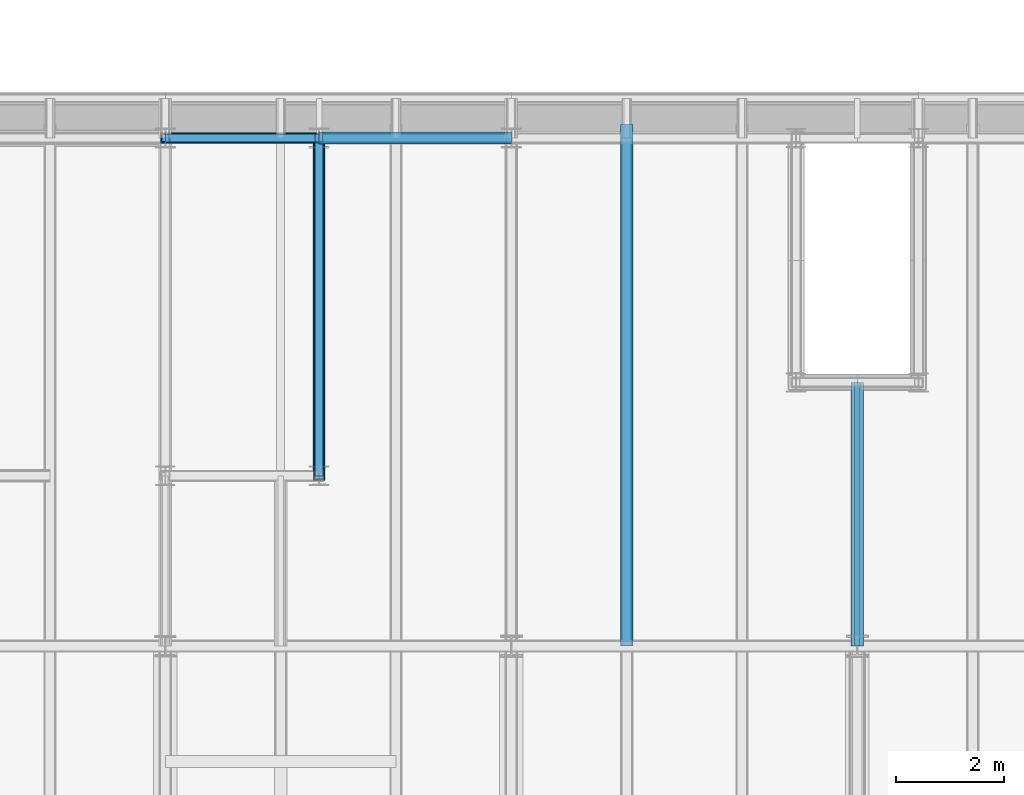
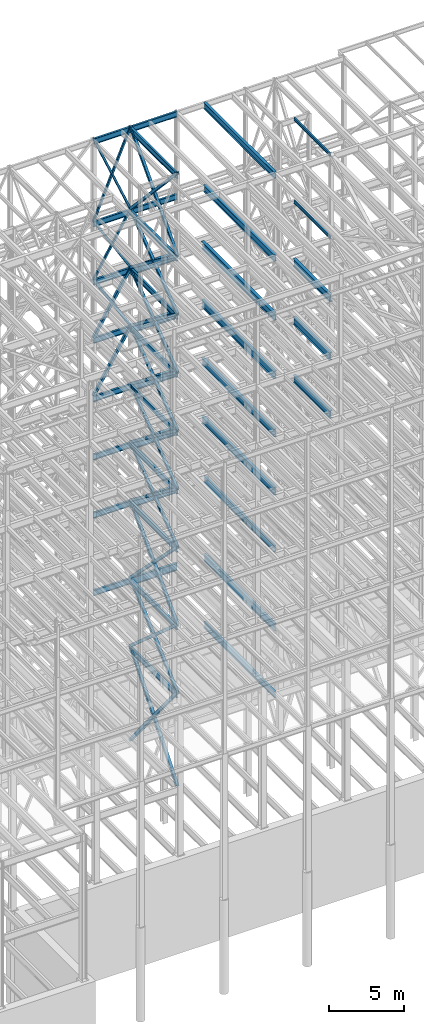
# One storey, part 142 of 150: 64 beams.
"""IFC2X3 building model written with IfcOpenShell, lengths in millimetres."""

from ifc_helpers import new_model, si_unit, frame, origin_with_axes, origin_2d_with_axis, place, context, subcontext, project, spatial, hollow_rectangle, i_section, extrude, material, type_object, element, save


model = new_model("IFC2X3")

# Units and contexts
model_context = context("Model", 3, precision=1e-05, world=origin_with_axes())
body_context = subcontext(model_context, "Body", "Model", "MODEL_VIEW")
ifc_project = project(units=[si_unit("LENGTHUNIT", "METRE", prefix="MILLI"), si_unit("AREAUNIT", "SQUARE_METRE"), si_unit("VOLUMEUNIT", "CUBIC_METRE"), si_unit("MASSUNIT", "GRAM", prefix="KILO"), si_unit("TIMEUNIT", "SECOND"), si_unit("PLANEANGLEUNIT", "RADIAN"), si_unit("SOLIDANGLEUNIT", "STERADIAN"), si_unit("THERMODYNAMICTEMPERATUREUNIT", "DEGREE_CELSIUS"), si_unit("LUMINOUSINTENSITYUNIT", "LUMEN")], contexts=[model_context])

# Site, building, storey
site_placement = place(None, origin_with_axes())
site = spatial("IfcSite", under=ifc_project, at=site_placement, CompositionType="ELEMENT")
building_placement = place(site_placement, origin_with_axes())
building = spatial("IfcBuilding", under=site, at=building_placement, Name="Undefined", CompositionType="ELEMENT")
storey_placement = place(building_placement, origin_with_axes())
storey = spatial("IfcBuildingStorey", under=building, at=storey_placement, Name="Undefined", CompositionType="ELEMENT", Elevation=0.0)

# Beams
ifc_material_1 = material()
beam_type_1 = type_object("IfcBeamType", Name="HSS8X8X3/8", PredefinedType="NOTDEFINED")
for number, where, z_axis, x_axis, name in (
    (1, (65836.8, 31877.0, 40309.8), (0.0, 0.603108242282795, 0.797659355922412), (0.0, -0.797659355922412, 0.603108242282795), "BEAM"),
    (2, (65836.8, 25628.6, 35585.4), (0.0, -0.603108242282795, 0.797659355922412), (0.0, 0.797659355922412, 0.603108242282795), "BEAM"),
    (3, (65836.8, 25628.6, 40309.8), (0.0, -0.603108242282795, 0.797659355922412), (0.0, 0.797659355922412, 0.603108242282795), "BEAM"),
    (4, (65836.8, 31877.0, 35585.4), (0.0, 0.603108242282795, 0.797659355922412), (0.0, -0.797659355922412, 0.603108242282795), "BEAM"),
):
    element("IfcBeam", number, at=place(storey_placement, frame(where, z_axis=z_axis, x_axis=x_axis)), inside=storey, type_object=beam_type_1, material=ifc_material_1, Name=name, ObjectType="HSS8X8X3/8", context=body_context, shape_type="SweptSolid", body=[
        extrude(hollow_rectangle(XDim=203.2, YDim=203.2, WallThickness=9.525, InnerFilletRadius=9.5249, OuterFilletRadius=19.0499, at=origin_2d_with_axis()), frame((7833.41929938644, 0.0, 0.0), z_axis=(-1.0, 0.0, 0.0), x_axis=(0.0, -1.0, 0.0)), (0.0, 0.0, 1.0), 7833.41929938644),
    ])
ifc_material_2 = material(Name="STEEL/A992")
beam_type_2 = type_object("IfcBeamType", Name="W18X35", PredefinedType="NOTDEFINED")
beam_1_placement = place(storey_placement, frame((62992.0, 31877.0, 65687.575), z_axis=(0.0, 0.0, 1.0), x_axis=(1.0, 0.0, 0.0)))
element("IfcBeam", 5, at=beam_1_placement, inside=storey, type_object=beam_type_2, material=ifc_material_2, Name="BEAM", ObjectType="W18X35", context=body_context, shape_type="SweptSolid", body=[
    extrude(i_section(OverallWidth=152.4, OverallDepth=450.85, WebThickness=7.9375, FlangeThickness=10.795, FilletRadius=17.78, at=origin_2d_with_axis()), frame((2844.8, 0.0, 0.0), z_axis=(-1.0, 0.0, 0.0), x_axis=(0.0, -1.0, 0.0)), (0.0, 0.0, 1.0), 2844.8),
])
beam_2_placement = place(storey_placement, frame((65836.8, 31877.0, 65687.575), z_axis=(0.0, 0.0, 1.0), x_axis=(1.0, 0.0, 0.0)))
element("IfcBeam", 6, at=beam_2_placement, inside=storey, type_object=beam_type_2, material=ifc_material_2, Name="BEAM", ObjectType="W18X35", context=body_context, shape_type="SweptSolid", body=[
    extrude(i_section(OverallWidth=152.4, OverallDepth=450.85, WebThickness=7.9375, FlangeThickness=10.795, FilletRadius=17.78, at=origin_2d_with_axis()), frame((3556.0, 0.0, 0.0), z_axis=(-1.0, 0.0, 0.0), x_axis=(0.0, -1.0, 0.0)), (0.0, 0.0, 1.0), 3556.0),
])
beam_3_placement = place(storey_placement, frame((62992.0, 31877.0, 58981.975), z_axis=(0.0, 0.0, 1.0), x_axis=(1.0, 0.0, 0.0)))
element("IfcBeam", 7, at=beam_3_placement, inside=storey, type_object=beam_type_2, material=ifc_material_2, Name="BEAM", ObjectType="W18X35", context=body_context, shape_type="SweptSolid", body=[
    extrude(i_section(OverallWidth=152.4, OverallDepth=450.85, WebThickness=7.9375, FlangeThickness=10.795, FilletRadius=17.78, at=origin_2d_with_axis()), frame((2844.8, 0.0, 0.0), z_axis=(-1.0, 0.0, 0.0), x_axis=(0.0, -1.0, 0.0)), (0.0, 0.0, 1.0), 2844.8),
])
beam_4_placement = place(storey_placement, frame((65836.8, 25628.6, 58981.975), z_axis=(0.0, 0.0, 1.0), x_axis=(0.0, 1.0, 0.0)))
element("IfcBeam", 8, at=beam_4_placement, inside=storey, type_object=beam_type_2, material=ifc_material_2, Name="BEAM", ObjectType="W18X35", context=body_context, shape_type="SweptSolid", body=[
    extrude(i_section(OverallWidth=152.4, OverallDepth=450.85, WebThickness=7.9375, FlangeThickness=10.795, FilletRadius=17.78, at=origin_2d_with_axis()), frame((6248.40000000001, 0.0, 0.0), z_axis=(-1.0, 0.0, 0.0), x_axis=(0.0, -1.0, 0.0)), (0.0, 0.0, 1.0), 6248.40000000001),
])
beam_5_placement = place(storey_placement, frame((65836.8, 31877.0, 58981.975), z_axis=(0.0, 0.0, 1.0), x_axis=(1.0, 0.0, 0.0)))
element("IfcBeam", 9, at=beam_5_placement, inside=storey, type_object=beam_type_2, material=ifc_material_2, Name="BEAM", ObjectType="W18X35", context=body_context, shape_type="SweptSolid", body=[
    extrude(i_section(OverallWidth=152.4, OverallDepth=450.85, WebThickness=7.9375, FlangeThickness=10.795, FilletRadius=17.78, at=origin_2d_with_axis()), frame((3556.0, 0.0, 0.0), z_axis=(-1.0, 0.0, 0.0), x_axis=(0.0, -1.0, 0.0)), (0.0, 0.0, 1.0), 3556.0),
])
beam_6_placement = place(storey_placement, frame((62992.0, 31877.0, 54257.575), z_axis=(0.0, 0.0, 1.0), x_axis=(1.0, 0.0, 0.0)))
element("IfcBeam", 10, at=beam_6_placement, inside=storey, type_object=beam_type_2, material=ifc_material_2, Name="BEAM", ObjectType="W18X35", context=body_context, shape_type="SweptSolid", body=[
    extrude(i_section(OverallWidth=152.4, OverallDepth=450.85, WebThickness=7.9375, FlangeThickness=10.795, FilletRadius=17.78, at=origin_2d_with_axis()), frame((2844.8, 0.0, 0.0), z_axis=(-1.0, 0.0, 0.0), x_axis=(0.0, -1.0, 0.0)), (0.0, 0.0, 1.0), 2844.8),
])
beam_7_placement = place(storey_placement, frame((65836.8, 25628.6, 54257.575), z_axis=(0.0, 0.0, 1.0), x_axis=(0.0, 1.0, 0.0)))
element("IfcBeam", 11, at=beam_7_placement, inside=storey, type_object=beam_type_2, material=ifc_material_2, Name="BEAM", ObjectType="W18X35", context=body_context, shape_type="SweptSolid", body=[
    extrude(i_section(OverallWidth=152.4, OverallDepth=450.85, WebThickness=7.9375, FlangeThickness=10.795, FilletRadius=17.78, at=origin_2d_with_axis()), frame((6248.40000000001, 0.0, 0.0), z_axis=(-1.0, 0.0, 0.0), x_axis=(0.0, -1.0, 0.0)), (0.0, 0.0, 1.0), 6248.40000000001),
])
beam_8_placement = place(storey_placement, frame((62992.0, 31877.0, 49533.175), z_axis=(0.0, 0.0, 1.0), x_axis=(1.0, 0.0, 0.0)))
element("IfcBeam", 12, at=beam_8_placement, inside=storey, type_object=beam_type_2, material=ifc_material_2, Name="BEAM", ObjectType="W18X35", context=body_context, shape_type="SweptSolid", body=[
    extrude(i_section(OverallWidth=152.4, OverallDepth=450.85, WebThickness=7.9375, FlangeThickness=10.795, FilletRadius=17.78, at=origin_2d_with_axis()), frame((2844.8, 0.0, 0.0), z_axis=(-1.0, 0.0, 0.0), x_axis=(0.0, -1.0, 0.0)), (0.0, 0.0, 1.0), 2844.8),
])
beam_9_placement = place(storey_placement, frame((65836.8, 25628.6, 49533.175), z_axis=(0.0, 0.0, 1.0), x_axis=(0.0, 1.0, 0.0)))
element("IfcBeam", 13, at=beam_9_placement, inside=storey, type_object=beam_type_2, material=ifc_material_2, Name="BEAM", ObjectType="W18X35", context=body_context, shape_type="SweptSolid", body=[
    extrude(i_section(OverallWidth=152.4, OverallDepth=450.85, WebThickness=7.9375, FlangeThickness=10.795, FilletRadius=17.78, at=origin_2d_with_axis()), frame((6248.40000000001, 0.0, 0.0), z_axis=(-1.0, 0.0, 0.0), x_axis=(0.0, -1.0, 0.0)), (0.0, 0.0, 1.0), 6248.40000000001),
])
beam_10_placement = place(storey_placement, frame((62992.0, 31877.0, 44808.775), z_axis=(0.0, 0.0, 1.0), x_axis=(1.0, 0.0, 0.0)))
element("IfcBeam", 14, at=beam_10_placement, inside=storey, type_object=beam_type_2, material=ifc_material_2, Name="BEAM", ObjectType="W18X35", context=body_context, shape_type="SweptSolid", body=[
    extrude(i_section(OverallWidth=152.4, OverallDepth=450.85, WebThickness=7.9375, FlangeThickness=10.795, FilletRadius=17.78, at=origin_2d_with_axis()), frame((2844.8, 0.0, 0.0), z_axis=(-1.0, 0.0, 0.0), x_axis=(0.0, -1.0, 0.0)), (0.0, 0.0, 1.0), 2844.8),
])
beam_11_placement = place(storey_placement, frame((65836.8, 25628.6, 44808.775), z_axis=(0.0, 0.0, 1.0), x_axis=(0.0, 1.0, 0.0)))
element("IfcBeam", 15, at=beam_11_placement, inside=storey, type_object=beam_type_2, material=ifc_material_2, Name="BEAM", ObjectType="W18X35", context=body_context, shape_type="SweptSolid", body=[
    extrude(i_section(OverallWidth=152.4, OverallDepth=450.85, WebThickness=7.9375, FlangeThickness=10.795, FilletRadius=17.78, at=origin_2d_with_axis()), frame((6248.40000000001, 0.0, 0.0), z_axis=(-1.0, 0.0, 0.0), x_axis=(0.0, -1.0, 0.0)), (0.0, 0.0, 1.0), 6248.40000000001),
])
beam_12_placement = place(storey_placement, frame((62992.0, 31877.0, 40084.375), z_axis=(0.0, 0.0, 1.0), x_axis=(1.0, 0.0, 0.0)))
element("IfcBeam", 16, at=beam_12_placement, inside=storey, type_object=beam_type_2, material=ifc_material_2, Name="BEAM", ObjectType="W18X35", context=body_context, shape_type="SweptSolid", body=[
    extrude(i_section(OverallWidth=152.4, OverallDepth=450.85, WebThickness=7.9375, FlangeThickness=10.795, FilletRadius=17.78, at=origin_2d_with_axis()), frame((2844.8, 0.0, 0.0), z_axis=(-1.0, 0.0, 0.0), x_axis=(0.0, -1.0, 0.0)), (0.0, 0.0, 1.0), 2844.8),
])
for number, where, z_axis, x_axis, name in (
    (17, (65836.8, 25628.6, 40084.375), (0.0, 0.0, 1.0), (0.0, 1.0, 0.0), "BEAM"),
    (18, (65836.8, 25628.6, 35359.975), (0.0, 0.0, 1.0), (0.0, 1.0, 0.0), "BEAM"),
):
    element("IfcBeam", number, at=place(storey_placement, frame(where, z_axis=z_axis, x_axis=x_axis)), inside=storey, type_object=beam_type_2, material=ifc_material_2, Name=name, ObjectType="W18X35", context=body_context, shape_type="SweptSolid", body=[
        extrude(i_section(OverallWidth=152.4, OverallDepth=450.85, WebThickness=7.9375, FlangeThickness=10.795, FilletRadius=17.78, at=origin_2d_with_axis()), frame((6248.40000000001, 0.0, 0.0), z_axis=(-1.0, 0.0, 0.0), x_axis=(0.0, -1.0, 0.0)), (0.0, 0.0, 1.0), 6248.40000000001),
    ])
beam_13_placement = place(storey_placement, frame((62992.0, 31877.0, 35359.975), z_axis=(0.0, 0.0, 1.0), x_axis=(1.0, 0.0, 0.0)))
element("IfcBeam", 19, at=beam_13_placement, inside=storey, type_object=beam_type_2, material=ifc_material_2, Name="BEAM", ObjectType="W18X35", context=body_context, shape_type="SweptSolid", body=[
    extrude(i_section(OverallWidth=152.4, OverallDepth=450.85, WebThickness=7.9375, FlangeThickness=10.795, FilletRadius=17.78, at=origin_2d_with_axis()), frame((2844.8, 0.0, 0.0), z_axis=(-1.0, 0.0, 0.0), x_axis=(0.0, -1.0, 0.0)), (0.0, 0.0, 1.0), 2844.8),
])
beam_14_placement = place(storey_placement, frame((62992.0, 31877.0, 29060.775), z_axis=(0.0, 0.0, 1.0), x_axis=(1.0, 0.0, 0.0)))
element("IfcBeam", 20, at=beam_14_placement, inside=storey, type_object=beam_type_2, material=ifc_material_2, Name="BEAM", ObjectType="W18X35", context=body_context, shape_type="SweptSolid", body=[
    extrude(i_section(OverallWidth=152.4, OverallDepth=450.85, WebThickness=7.9375, FlangeThickness=10.795, FilletRadius=17.78, at=origin_2d_with_axis()), frame((2844.8, 0.0, 0.0), z_axis=(-1.0, 0.0, 0.0), x_axis=(0.0, -1.0, 0.0)), (0.0, 0.0, 1.0), 2844.79999999999),
])
for number, where, z_axis, x_axis, name in (
    (21, (65836.8, 25628.6, 29060.775), (0.0, 0.0, 1.0), (0.0, 1.0, 0.0), "BEAM"),
    (22, (65836.8, 25628.6, 23548.975), (0.0, 0.0, 1.0), (0.0, 1.0, 0.0), "BEAM"),
):
    element("IfcBeam", number, at=place(storey_placement, frame(where, z_axis=z_axis, x_axis=x_axis)), inside=storey, type_object=beam_type_2, material=ifc_material_2, Name=name, ObjectType="W18X35", context=body_context, shape_type="SweptSolid", body=[
        extrude(i_section(OverallWidth=152.4, OverallDepth=450.85, WebThickness=7.9375, FlangeThickness=10.795, FilletRadius=17.78, at=origin_2d_with_axis()), frame((6248.40000000001, 0.0, 0.0), z_axis=(-1.0, 0.0, 0.0), x_axis=(0.0, -1.0, 0.0)), (0.0, 0.0, 1.0), 6248.40000000001),
    ])
beam_type_3 = type_object("IfcBeamType", Name="HSS8X8X1/4", PredefinedType="NOTDEFINED")
beam_15_placement = place(storey_placement, frame((65836.8, 31877.0, 59207.4), z_axis=(0.0, 0.73160793181113, 0.681725629642191), x_axis=(0.0, -0.681725629642191, 0.731607931811129)))
element("IfcBeam", 23, at=beam_15_placement, inside=storey, type_object=beam_type_3, material=ifc_material_1, Name="BEAM", ObjectType="HSS8X8X1/4", context=body_context, shape_type="SweptSolid", body=[
    extrude(hollow_rectangle(XDim=203.2, YDim=203.2, WallThickness=6.35, InnerFilletRadius=6.3499, OuterFilletRadius=12.6999, at=origin_2d_with_axis()), frame((9165.56457180898, 0.0, -7.27595761418343e-12), z_axis=(-1.0, 0.0, 0.0), x_axis=(0.0, -1.0, 0.0)), (0.0, 0.0, 1.0), 9165.56457180899),
])
for number, where, z_axis, x_axis, name in (
    (24, (65836.8, 25628.6, 54483.0), (0.0, -0.603108242282795, 0.797659355922412), (0.0, 0.797659355922412, 0.603108242282795), "BEAM"),
    (25, (65836.8, 31877.0, 49758.6), (0.0, 0.603108242282795, 0.797659355922412), (0.0, -0.797659355922412, 0.603108242282795), "BEAM"),
    (26, (65836.8, 25628.6, 45034.2), (0.0, -0.603108242282795, 0.797659355922412), (0.0, 0.797659355922412, 0.603108242282795), "BEAM"),
):
    element("IfcBeam", number, at=place(storey_placement, frame(where, z_axis=z_axis, x_axis=x_axis)), inside=storey, type_object=beam_type_3, material=ifc_material_1, Name=name, ObjectType="HSS8X8X1/4", context=body_context, shape_type="SweptSolid", body=[
        extrude(hollow_rectangle(XDim=203.2, YDim=203.2, WallThickness=6.35, InnerFilletRadius=6.3499, OuterFilletRadius=12.6999, at=origin_2d_with_axis()), frame((7833.41929938644, 0.0, 0.0), z_axis=(-1.0, 0.0, 0.0), x_axis=(0.0, -1.0, 0.0)), (0.0, 0.0, 1.0), 7833.41929938644),
    ])
beam_16_placement = place(storey_placement, frame((65836.8, 25628.6, 59207.4), z_axis=(0.0, -0.73160798168672, 0.681725576117168), x_axis=(0.0, 0.681725576117167, 0.731607981686721)))
element("IfcBeam", 27, at=beam_16_placement, inside=storey, type_object=beam_type_3, material=ifc_material_1, Name="BEAM", ObjectType="HSS8X8X1/4", context=body_context, shape_type="SweptSolid", body=[
    extrude(hollow_rectangle(XDim=203.2, YDim=203.2, WallThickness=6.35, InnerFilletRadius=6.3499, OuterFilletRadius=12.6999, at=origin_2d_with_axis()), frame((9165.56457180898, 0.0, -7.27595761418343e-12), z_axis=(-1.0, 0.0, 0.0), x_axis=(0.0, -1.0, 0.0)), (0.0, 0.0, 1.0), 9165.56457180899),
])
for number, where, z_axis, x_axis, name in (
    (28, (65836.8, 31877.0, 54483.0), (0.0, 0.603108242282795, 0.797659355922412), (0.0, -0.797659355922412, 0.603108242282795), "BEAM"),
    (29, (65836.8, 25628.6, 49758.6), (0.0, -0.603108242282795, 0.797659355922412), (0.0, 0.797659355922412, 0.603108242282795), "BEAM"),
    (30, (65836.8, 31877.0, 45034.2), (0.0, 0.603108242282795, 0.797659355922412), (0.0, -0.797659355922412, 0.603108242282795), "BEAM"),
):
    element("IfcBeam", number, at=place(storey_placement, frame(where, z_axis=z_axis, x_axis=x_axis)), inside=storey, type_object=beam_type_3, material=ifc_material_1, Name=name, ObjectType="HSS8X8X1/4", context=body_context, shape_type="SweptSolid", body=[
        extrude(hollow_rectangle(XDim=203.2, YDim=203.2, WallThickness=6.35, InnerFilletRadius=6.3499, OuterFilletRadius=12.6999, at=origin_2d_with_axis()), frame((7833.41929938644, 0.0, 0.0), z_axis=(-1.0, 0.0, 0.0), x_axis=(0.0, -1.0, 0.0)), (0.0, 0.0, 1.0), 7833.41929938644),
    ])
beam_17_placement = place(storey_placement, frame((62992.0, 31877.0, 45034.2), z_axis=(-0.856679076231124, 0.0, 0.515849745902611), x_axis=(0.51584974590261, 0.0, 0.856679076231124)))
element("IfcBeam", 31, at=beam_17_placement, inside=storey, type_object=beam_type_3, material=ifc_material_1, Name="BEAM", ObjectType="HSS8X8X1/4", context=body_context, shape_type="SweptSolid", body=[
    extrude(hollow_rectangle(XDim=203.2, YDim=203.2, WallThickness=6.35, InnerFilletRadius=6.3499, OuterFilletRadius=12.6999, at=origin_2d_with_axis()), frame((5514.78398489006, -3.63797880709171e-12, 0.0), z_axis=(-1.0, 0.0, 0.0), x_axis=(0.0, -1.0, 0.0)), (0.0, 0.0, 1.0), 5514.78398489007),
])
beam_18_placement = place(storey_placement, frame((65836.8, 31877.0, 49758.6), z_axis=(0.856679076231126, 0.0, 0.515849745902608), x_axis=(-0.515849745902611, 0.0, 0.856679076231124)))
element("IfcBeam", 32, at=beam_18_placement, inside=storey, type_object=beam_type_3, material=ifc_material_1, Name="BEAM", ObjectType="HSS8X8X1/4", context=body_context, shape_type="SweptSolid", body=[
    extrude(hollow_rectangle(XDim=203.2, YDim=203.2, WallThickness=6.35, InnerFilletRadius=6.3499, OuterFilletRadius=12.6999, at=origin_2d_with_axis()), frame((5514.78398489006, -3.63797880709171e-12, 0.0), z_axis=(-1.0, 0.0, 0.0), x_axis=(0.0, -1.0, 0.0)), (0.0, 0.0, 1.0), 5514.78398489006),
])
beam_19_placement = place(storey_placement, frame((62992.0, 31877.0, 49758.6), z_axis=(-0.856679076231124, 0.0, 0.515849745902611), x_axis=(0.51584974590261, 0.0, 0.856679076231124)))
element("IfcBeam", 33, at=beam_19_placement, inside=storey, type_object=beam_type_3, material=ifc_material_1, Name="BEAM", ObjectType="HSS8X8X1/4", context=body_context, shape_type="SweptSolid", body=[
    extrude(hollow_rectangle(XDim=203.2, YDim=203.2, WallThickness=6.35, InnerFilletRadius=6.3499, OuterFilletRadius=12.6999, at=origin_2d_with_axis()), frame((5514.78398489006, -3.63797880709171e-12, 0.0), z_axis=(-1.0, 0.0, 0.0), x_axis=(0.0, -1.0, 0.0)), (0.0, 0.0, 1.0), 5514.78398489008),
])
beam_type_4 = type_object("IfcBeamType", Name="HSS6X6X1/4", PredefinedType="NOTDEFINED")
beam_20_placement = place(storey_placement, frame((65836.8, 31877.0, 54483.0), z_axis=(0.856679076231126, 0.0, 0.515849745902608), x_axis=(-0.515849745902611, 0.0, 0.856679076231124)))
element("IfcBeam", 34, at=beam_20_placement, inside=storey, type_object=beam_type_4, material=ifc_material_1, Name="BEAM", ObjectType="HSS6X6X1/4", context=body_context, shape_type="SweptSolid", body=[
    extrude(hollow_rectangle(XDim=152.4, YDim=152.4, WallThickness=6.35, InnerFilletRadius=6.3499, OuterFilletRadius=12.6999, at=origin_2d_with_axis()), frame((5514.78398489006, -3.63797880709171e-12, 0.0), z_axis=(-1.0, 0.0, 0.0), x_axis=(0.0, -1.0, 0.0)), (0.0, 0.0, 1.0), 5514.78398489006),
])
beam_21_placement = place(storey_placement, frame((62992.0, 31877.0, 54483.0), z_axis=(-0.856679076231124, 0.0, 0.515849745902611), x_axis=(0.51584974590261, 0.0, 0.856679076231124)))
element("IfcBeam", 35, at=beam_21_placement, inside=storey, type_object=beam_type_4, material=ifc_material_1, Name="BEAM", ObjectType="HSS6X6X1/4", context=body_context, shape_type="SweptSolid", body=[
    extrude(hollow_rectangle(XDim=152.4, YDim=152.4, WallThickness=6.35, InnerFilletRadius=6.3499, OuterFilletRadius=12.6999, at=origin_2d_with_axis()), frame((5514.78398489006, -3.63797880709171e-12, 0.0), z_axis=(-1.0, 0.0, 0.0), x_axis=(0.0, -1.0, 0.0)), (0.0, 0.0, 1.0), 5514.78398489007),
])
for number, where, z_axis, x_axis, name in (
    (36, (65836.8, 31877.0, 59207.4), (0.920581786233233, 0.0, 0.390549836583797), (-0.390549836583795, 0.0, 0.920581786233234), "BEAM"),
    (37, (62992.0, 31877.0, 59207.4), (-0.920581786233234, 0.0, 0.390549836583795), (0.390549836583795, 0.0, 0.920581786233234), "BEAM"),
):
    element("IfcBeam", number, at=place(storey_placement, frame(where, z_axis=z_axis, x_axis=x_axis)), inside=storey, type_object=beam_type_4, material=ifc_material_1, Name=name, ObjectType="HSS6X6X1/4", context=body_context, shape_type="SweptSolid", body=[
        extrude(hollow_rectangle(XDim=152.4, YDim=152.4, WallThickness=6.35, InnerFilletRadius=6.3499, OuterFilletRadius=12.6999, at=origin_2d_with_axis()), frame((7284.08940087915, 0.0, -4.04348188314205e-13), z_axis=(-1.0, 0.0, 0.0), x_axis=(0.0, -1.0, 0.0)), (0.0, 0.0, 1.0), 7284.08940087915),
    ])
beam_type_5 = type_object("IfcBeamType", Name="HSS9X9X1/2", PredefinedType="NOTDEFINED")
beam_22_placement = place(storey_placement, frame((65836.8, 31877.0, 29286.2), z_axis=(0.0, 0.709963736329935, 0.704238236036952), x_axis=(0.0, -0.704238236036953, 0.709963736329935)))
element("IfcBeam", 38, at=beam_22_placement, inside=storey, type_object=beam_type_5, material=ifc_material_1, Name="BEAM", ObjectType="HSS9X9X1/2", context=body_context, shape_type="SweptSolid", body=[
    extrude(hollow_rectangle(XDim=228.6, YDim=228.6, WallThickness=12.7, InnerFilletRadius=12.6999, OuterFilletRadius=25.3999, at=origin_2d_with_axis()), frame((8872.56576194282, 0.0, 0.0), z_axis=(-1.0, 0.0, 0.0), x_axis=(0.0, -1.0, 0.0)), (0.0, 0.0, 1.0), 8872.56576194282),
])
beam_23_placement = place(storey_placement, frame((65836.8, 25628.6, 23774.4), z_axis=(0.0, -0.661520808536634, 0.749926809677477), x_axis=(0.0, 0.749926809677476, 0.661520808536635)))
element("IfcBeam", 39, at=beam_23_placement, inside=storey, type_object=beam_type_5, material=ifc_material_1, Name="BEAM", ObjectType="HSS9X9X1/2", context=body_context, shape_type="SweptSolid", body=[
    extrude(hollow_rectangle(XDim=228.6, YDim=228.6, WallThickness=12.7, InnerFilletRadius=12.6999, OuterFilletRadius=25.3999, at=origin_2d_with_axis()), frame((8332.01307008096, 0.0, -9.25039275188162e-13), z_axis=(-1.0, 0.0, 0.0), x_axis=(0.0, -1.0, 0.0)), (0.0, 0.0, 1.0), 8332.01307008097),
])
beam_24_placement = place(storey_placement, frame((65836.8, 31877.0, 16154.4), z_axis=(0.0, 0.773267797360785, 0.634079579835843), x_axis=(0.0, -0.634079579835843, 0.773267797360786)))
element("IfcBeam", 40, at=beam_24_placement, inside=storey, type_object=beam_type_5, material=ifc_material_1, Name="BEAM", ObjectType="HSS9X9X1/2", context=body_context, shape_type="SweptSolid", body=[
    extrude(hollow_rectangle(XDim=228.6, YDim=228.6, WallThickness=12.7, InnerFilletRadius=12.6999, OuterFilletRadius=25.3999, at=origin_2d_with_axis()), frame((9854.28346253547, 0.0, 5.47022619564489e-13), z_axis=(-1.0, 0.0, 0.0), x_axis=(0.0, -1.0, 0.0)), (0.0, 0.0, 1.0), 9854.28346253547),
])
beam_25_placement = place(storey_placement, frame((65836.8, 25628.6, 29286.2), z_axis=(0.0, -0.709963736329935, 0.704238236036952), x_axis=(0.0, 0.704238236036953, 0.709963736329935)))
element("IfcBeam", 41, at=beam_25_placement, inside=storey, type_object=beam_type_5, material=ifc_material_1, Name="BEAM", ObjectType="HSS9X9X1/2", context=body_context, shape_type="SweptSolid", body=[
    extrude(hollow_rectangle(XDim=228.6, YDim=228.6, WallThickness=12.7, InnerFilletRadius=12.6999, OuterFilletRadius=25.3999, at=origin_2d_with_axis()), frame((8872.56527289995, 0.0, 4.92526312673155e-13), z_axis=(-1.0, 0.0, 0.0), x_axis=(0.0, -1.0, 0.0)), (0.0, 0.0, 1.0), 8872.56527289995),
])
beam_26_placement = place(storey_placement, frame((65836.8, 31877.0, 23774.4), z_axis=(0.0, 0.661520808536634, 0.749926809677477), x_axis=(0.0, -0.749926809677476, 0.661520808536635)))
element("IfcBeam", 42, at=beam_26_placement, inside=storey, type_object=beam_type_5, material=ifc_material_1, Name="BEAM", ObjectType="HSS9X9X1/2", context=body_context, shape_type="SweptSolid", body=[
    extrude(hollow_rectangle(XDim=228.6, YDim=228.6, WallThickness=12.7, InnerFilletRadius=12.6999, OuterFilletRadius=25.3999, at=origin_2d_with_axis()), frame((8332.01307008096, 0.0, -9.25039275188162e-13), z_axis=(-1.0, 0.0, 0.0), x_axis=(0.0, -1.0, 0.0)), (0.0, 0.0, 1.0), 8332.01307008096),
])
beam_27_placement = place(storey_placement, frame((65836.8, 25628.6, 16154.4), z_axis=(0.0, -0.773267797360785, 0.634079579835843), x_axis=(0.0, 0.634079579835843, 0.773267797360786)))
element("IfcBeam", 43, at=beam_27_placement, inside=storey, type_object=beam_type_5, material=ifc_material_1, Name="BEAM", ObjectType="HSS9X9X1/2", context=body_context, shape_type="SweptSolid", body=[
    extrude(hollow_rectangle(XDim=228.6, YDim=228.6, WallThickness=12.7, InnerFilletRadius=12.6999, OuterFilletRadius=25.3999, at=origin_2d_with_axis()), frame((9854.28346253547, 0.0, 5.47022619564489e-13), z_axis=(-1.0, 0.0, 0.0), x_axis=(0.0, -1.0, 0.0)), (0.0, 0.0, 1.0), 9854.28346253547),
])
beam_type_6 = type_object("IfcBeamType", Name="W24X68", PredefinedType="NOTDEFINED")
beam_28_placement = place(storey_placement, frame((75793.6, 22479.0, 54181.375), z_axis=(0.0, 0.0, 1.0), x_axis=(0.0, 1.0, 0.0)))
element("IfcBeam", 44, at=beam_28_placement, inside=storey, type_object=beam_type_6, material=ifc_material_2, Name="BEAM", ObjectType="W24X68", context=body_context, shape_type="SweptSolid", body=[
    extrude(i_section(OverallWidth=227.838, OverallDepth=603.25, WebThickness=11.1125, FlangeThickness=14.859, FilletRadius=23.2409, at=origin_2d_with_axis()), frame((4876.8, 0.0, 0.0), z_axis=(-1.0, 0.0, 0.0), x_axis=(0.0, -1.0, 0.0)), (0.0, 0.0, 1.0), 4876.8),
])
beam_29_placement = place(storey_placement, frame((71526.4, 22479.0, 54181.375), z_axis=(0.0, 0.0, 1.0), x_axis=(0.0, 1.0, 0.0)))
element("IfcBeam", 45, at=beam_29_placement, inside=storey, type_object=beam_type_6, material=ifc_material_2, Name="BEAM", ObjectType="W24X68", context=body_context, shape_type="SweptSolid", body=[
    extrude(i_section(OverallWidth=227.838, OverallDepth=603.25, WebThickness=11.1125, FlangeThickness=14.859, FilletRadius=23.2409, at=origin_2d_with_axis()), frame((9652.0, 0.0, 0.0), z_axis=(-1.0, 0.0, 0.0), x_axis=(0.0, -1.0, 0.0)), (0.0, 0.0, 1.0), 9652.0),
])
beam_30_placement = place(storey_placement, frame((65836.8, 31877.0, 54181.375), z_axis=(0.0, 0.0, 1.0), x_axis=(1.0, 0.0, 0.0)))
element("IfcBeam", 46, at=beam_30_placement, inside=storey, type_object=beam_type_6, material=ifc_material_2, Name="BEAM", ObjectType="W24X68", context=body_context, shape_type="SweptSolid", body=[
    extrude(i_section(OverallWidth=227.838, OverallDepth=603.25, WebThickness=11.1125, FlangeThickness=14.859, FilletRadius=23.2409, at=origin_2d_with_axis()), frame((3556.0, 0.0, 0.0), z_axis=(-1.0, 0.0, 0.0), x_axis=(0.0, -1.0, 0.0)), (0.0, 0.0, 1.0), 3556.0),
])
beam_31_placement = place(storey_placement, frame((75793.6, 22479.0, 49456.975), z_axis=(0.0, 0.0, 1.0), x_axis=(0.0, 1.0, 0.0)))
element("IfcBeam", 47, at=beam_31_placement, inside=storey, type_object=beam_type_6, material=ifc_material_2, Name="BEAM", ObjectType="W24X68", context=body_context, shape_type="SweptSolid", body=[
    extrude(i_section(OverallWidth=227.838, OverallDepth=603.25, WebThickness=11.1125, FlangeThickness=14.859, FilletRadius=23.2409, at=origin_2d_with_axis()), frame((4876.8, 0.0, 0.0), z_axis=(-1.0, 0.0, 0.0), x_axis=(0.0, -1.0, 0.0)), (0.0, 0.0, 1.0), 4876.8),
])
beam_32_placement = place(storey_placement, frame((71526.4, 22479.0, 49456.975), z_axis=(0.0, 0.0, 1.0), x_axis=(0.0, 1.0, 0.0)))
element("IfcBeam", 48, at=beam_32_placement, inside=storey, type_object=beam_type_6, material=ifc_material_2, Name="BEAM", ObjectType="W24X68", context=body_context, shape_type="SweptSolid", body=[
    extrude(i_section(OverallWidth=227.838, OverallDepth=603.25, WebThickness=11.1125, FlangeThickness=14.859, FilletRadius=23.2409, at=origin_2d_with_axis()), frame((9652.0, 0.0, 0.0), z_axis=(-1.0, 0.0, 0.0), x_axis=(0.0, -1.0, 0.0)), (0.0, 0.0, 1.0), 9652.0),
])
beam_33_placement = place(storey_placement, frame((65836.8, 31877.0, 49456.975), z_axis=(0.0, 0.0, 1.0), x_axis=(1.0, 0.0, 0.0)))
element("IfcBeam", 49, at=beam_33_placement, inside=storey, type_object=beam_type_6, material=ifc_material_2, Name="BEAM", ObjectType="W24X68", context=body_context, shape_type="SweptSolid", body=[
    extrude(i_section(OverallWidth=227.838, OverallDepth=603.25, WebThickness=11.1125, FlangeThickness=14.859, FilletRadius=23.2409, at=origin_2d_with_axis()), frame((3556.0, 0.0, 0.0), z_axis=(-1.0, 0.0, 0.0), x_axis=(0.0, -1.0, 0.0)), (0.0, 0.0, 1.0), 3556.0),
])
beam_34_placement = place(storey_placement, frame((75793.6, 22479.0, 44732.575), z_axis=(0.0, 0.0, 1.0), x_axis=(0.0, 1.0, 0.0)))
element("IfcBeam", 50, at=beam_34_placement, inside=storey, type_object=beam_type_6, material=ifc_material_2, Name="BEAM", ObjectType="W24X68", context=body_context, shape_type="SweptSolid", body=[
    extrude(i_section(OverallWidth=227.838, OverallDepth=603.25, WebThickness=11.1125, FlangeThickness=14.859, FilletRadius=23.2409, at=origin_2d_with_axis()), frame((4876.8, 0.0, 0.0), z_axis=(-1.0, 0.0, 0.0), x_axis=(0.0, -1.0, 0.0)), (0.0, 0.0, 1.0), 4876.8),
])
beam_35_placement = place(storey_placement, frame((71526.4, 22479.0, 44732.575), z_axis=(0.0, 0.0, 1.0), x_axis=(0.0, 1.0, 0.0)))
element("IfcBeam", 51, at=beam_35_placement, inside=storey, type_object=beam_type_6, material=ifc_material_2, Name="BEAM", ObjectType="W24X68", context=body_context, shape_type="SweptSolid", body=[
    extrude(i_section(OverallWidth=227.838, OverallDepth=603.25, WebThickness=11.1125, FlangeThickness=14.859, FilletRadius=23.2409, at=origin_2d_with_axis()), frame((9652.0, 0.0, 0.0), z_axis=(-1.0, 0.0, 0.0), x_axis=(0.0, -1.0, 0.0)), (0.0, 0.0, 1.0), 9652.0),
])
beam_36_placement = place(storey_placement, frame((65836.8, 31877.0, 44732.575), z_axis=(0.0, 0.0, 1.0), x_axis=(1.0, 0.0, 0.0)))
element("IfcBeam", 52, at=beam_36_placement, inside=storey, type_object=beam_type_6, material=ifc_material_2, Name="BEAM", ObjectType="W24X68", context=body_context, shape_type="SweptSolid", body=[
    extrude(i_section(OverallWidth=227.838, OverallDepth=603.25, WebThickness=11.1125, FlangeThickness=14.859, FilletRadius=23.2409, at=origin_2d_with_axis()), frame((3556.0, 0.0, 0.0), z_axis=(-1.0, 0.0, 0.0), x_axis=(0.0, -1.0, 0.0)), (0.0, 0.0, 1.0), 3556.0),
])
beam_37_placement = place(storey_placement, frame((71526.4, 22479.0, 40008.175), z_axis=(0.0, 0.0, 1.0), x_axis=(0.0, 1.0, 0.0)))
element("IfcBeam", 53, at=beam_37_placement, inside=storey, type_object=beam_type_6, material=ifc_material_2, Name="BEAM", ObjectType="W24X68", context=body_context, shape_type="SweptSolid", body=[
    extrude(i_section(OverallWidth=227.838, OverallDepth=603.25, WebThickness=11.1125, FlangeThickness=14.859, FilletRadius=23.2409, at=origin_2d_with_axis()), frame((9652.0, 0.0, 0.0), z_axis=(-1.0, 0.0, 0.0), x_axis=(0.0, -1.0, 0.0)), (0.0, 0.0, 1.0), 9652.0),
])
beam_38_placement = place(storey_placement, frame((65836.8, 31877.0, 40008.175), z_axis=(0.0, 0.0, 1.0), x_axis=(1.0, 0.0, 0.0)))
element("IfcBeam", 54, at=beam_38_placement, inside=storey, type_object=beam_type_6, material=ifc_material_2, Name="BEAM", ObjectType="W24X68", context=body_context, shape_type="SweptSolid", body=[
    extrude(i_section(OverallWidth=227.838, OverallDepth=603.25, WebThickness=11.1125, FlangeThickness=14.859, FilletRadius=23.2409, at=origin_2d_with_axis()), frame((3556.0, 0.0, 0.0), z_axis=(-1.0, 0.0, 0.0), x_axis=(0.0, -1.0, 0.0)), (0.0, 0.0, 1.0), 3556.0),
])
beam_type_7 = type_object("IfcBeamType", Name="W21X55", PredefinedType="NOTDEFINED")
for number, where, z_axis, x_axis, name in (
    (55, (71526.4, 22479.0, 65649.475), (0.0, 0.0, 1.0), (0.0, 1.0, 0.0), "BEAM"),
    (56, (71526.4, 22479.0, 58943.875), (0.0, 0.0, 1.0), (0.0, 1.0, 0.0), "BEAM"),
):
    element("IfcBeam", number, at=place(storey_placement, frame(where, z_axis=z_axis, x_axis=x_axis)), inside=storey, type_object=beam_type_7, material=ifc_material_2, Name=name, ObjectType="W21X55", context=body_context, shape_type="SweptSolid", body=[
        extrude(i_section(OverallWidth=208.788, OverallDepth=527.05, WebThickness=9.5, FlangeThickness=13.2588, FilletRadius=16.8624, at=origin_2d_with_axis()), frame((9398.0, 0.0, 0.0), z_axis=(-1.0, 0.0, 0.0), x_axis=(0.0, -1.0, 0.0)), (0.0, 0.0, 1.0), 9398.0),
    ])
beam_type_8 = type_object("IfcBeamType", Name="W10X15", PredefinedType="NOTDEFINED")
for number, where, z_axis, x_axis, name in (
    (57, (75793.6, 22479.0, 65786.0), (0.0, 0.0, 1.0), (0.0, 1.0, 0.0), "BEAM"),
    (58, (75793.6, 22479.0, 59080.4), (0.0, 0.0, 1.0), (0.0, 1.0, 0.0), "BEAM"),
):
    element("IfcBeam", number, at=place(storey_placement, frame(where, z_axis=z_axis, x_axis=x_axis)), inside=storey, type_object=beam_type_8, material=ifc_material_2, Name=name, ObjectType="W10X15", context=body_context, shape_type="SweptSolid", body=[
        extrude(i_section(OverallWidth=101.6, OverallDepth=254.0, WebThickness=6.3499, FlangeThickness=6.858, FilletRadius=13.7795, at=origin_2d_with_axis()), frame((4876.8, 0.0, 0.0), z_axis=(-1.0, 0.0, 0.0), x_axis=(0.0, -1.0, 0.0)), (0.0, 0.0, 1.0), 4876.8),
    ])
beam_type_9 = type_object("IfcBeamType", Name="W18X40", PredefinedType="NOTDEFINED")
beam_39_placement = place(storey_placement, frame((65836.8, 25628.6, 65685.9875), z_axis=(0.0, 0.0, 1.0), x_axis=(0.0, 1.0, 0.0)))
element("IfcBeam", 59, at=beam_39_placement, inside=storey, type_object=beam_type_9, material=ifc_material_2, Name="BEAM", ObjectType="W18X40", context=body_context, shape_type="SweptSolid", body=[
    extrude(i_section(OverallWidth=152.908, OverallDepth=454.025, WebThickness=7.9375, FlangeThickness=13.335, FilletRadius=16.8274, at=origin_2d_with_axis()), frame((6248.40000000001, 0.0, 0.0), z_axis=(-1.0, 0.0, 0.0), x_axis=(0.0, -1.0, 0.0)), (0.0, 0.0, 1.0), 6248.40000000001),
])
beam_type_10 = type_object("IfcBeamType", Name="W24X55", PredefinedType="NOTDEFINED")
beam_40_placement = place(storey_placement, frame((65836.8, 31877.0, 28986.1625), z_axis=(0.0, 0.0, 1.0), x_axis=(1.0, 0.0, 0.0)))
element("IfcBeam", 60, at=beam_40_placement, inside=storey, type_object=beam_type_10, material=ifc_material_2, Name="BEAM", ObjectType="W24X55", context=body_context, shape_type="SweptSolid", body=[
    extrude(i_section(OverallWidth=178.054, OverallDepth=600.075, WebThickness=9.5249, FlangeThickness=12.827, FilletRadius=23.6854, at=origin_2d_with_axis()), frame((3556.0, 0.0, 0.0), z_axis=(-1.0, 0.0, 0.0), x_axis=(0.0, -1.0, 0.0)), (0.0, 0.0, 1.0), 3556.0),
])
beam_41_placement = place(storey_placement, frame((71526.4, 22479.0, 28986.1625), z_axis=(0.0, 0.0, 1.0), x_axis=(0.0, 1.0, 0.0)))
element("IfcBeam", 61, at=beam_41_placement, inside=storey, type_object=beam_type_10, material=ifc_material_2, Name="BEAM", ObjectType="W24X55", context=body_context, shape_type="SweptSolid", body=[
    extrude(i_section(OverallWidth=178.054, OverallDepth=600.075, WebThickness=9.5249, FlangeThickness=12.827, FilletRadius=23.6854, at=origin_2d_with_axis()), frame((9398.0, 0.0, 0.0), z_axis=(-1.0, 0.0, 0.0), x_axis=(0.0, -1.0, 0.0)), (0.0, 0.0, 1.0), 9398.00000000001),
])
beam_type_11 = type_object("IfcBeamType", Name="W21X44", PredefinedType="NOTDEFINED")
for number, where, z_axis, x_axis, name in (
    (62, (71526.39935992, 22479.0, 35323.4625), (0.0, 0.0, 1.0), (0.0, 1.0, 0.0), "BEAM"),
    (63, (71526.4, 22479.0, 23512.4625), (0.0, 0.0, 1.0), (0.0, 1.0, 0.0), "BEAM"),
):
    element("IfcBeam", number, at=place(storey_placement, frame(where, z_axis=z_axis, x_axis=x_axis)), inside=storey, type_object=beam_type_11, material=ifc_material_2, Name=name, ObjectType="W21X44", context=body_context, shape_type="SweptSolid", body=[
        extrude(i_section(OverallWidth=165.1, OverallDepth=523.875, WebThickness=9.5249, FlangeThickness=11.43, FilletRadius=17.145, at=origin_2d_with_axis()), frame((9398.0, 0.0, 0.0), z_axis=(-1.0, 0.0, 0.0), x_axis=(0.0, -1.0, 0.0)), (0.0, 0.0, 1.0), 9398.00000000001),
    ])
beam_type_12 = type_object("IfcBeamType", Name="W24X62", PredefinedType="NOTDEFINED")
beam_42_placement = place(storey_placement, frame((65836.8, 31877.0, 35283.775), z_axis=(0.0, 0.0, 1.0), x_axis=(1.0, 0.0, 0.0)))
element("IfcBeam", 64, at=beam_42_placement, inside=storey, type_object=beam_type_12, material=ifc_material_2, Name="BEAM", ObjectType="W24X62", context=body_context, shape_type="SweptSolid", body=[
    extrude(i_section(OverallWidth=177.8, OverallDepth=603.25, WebThickness=11.1125, FlangeThickness=14.986, FilletRadius=23.114, at=origin_2d_with_axis()), frame((3556.0, 0.0, 0.0), z_axis=(-1.0, 0.0, 0.0), x_axis=(0.0, -1.0, 0.0)), (0.0, 0.0, 1.0), 3556.0),
])

save(model, "model.ifc")
